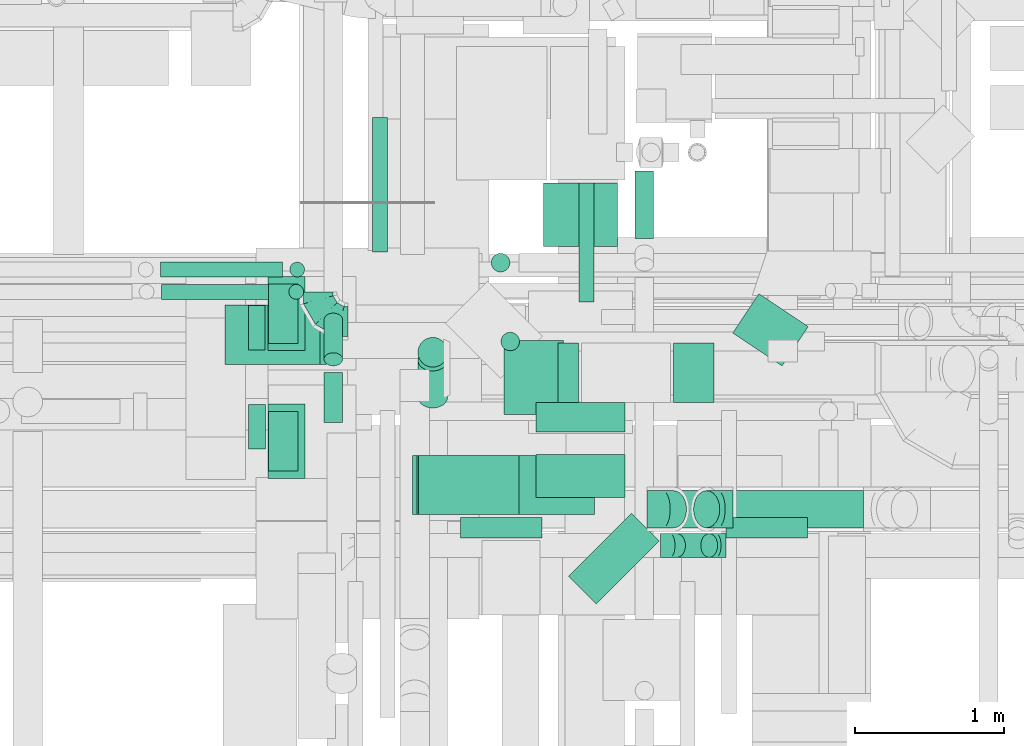
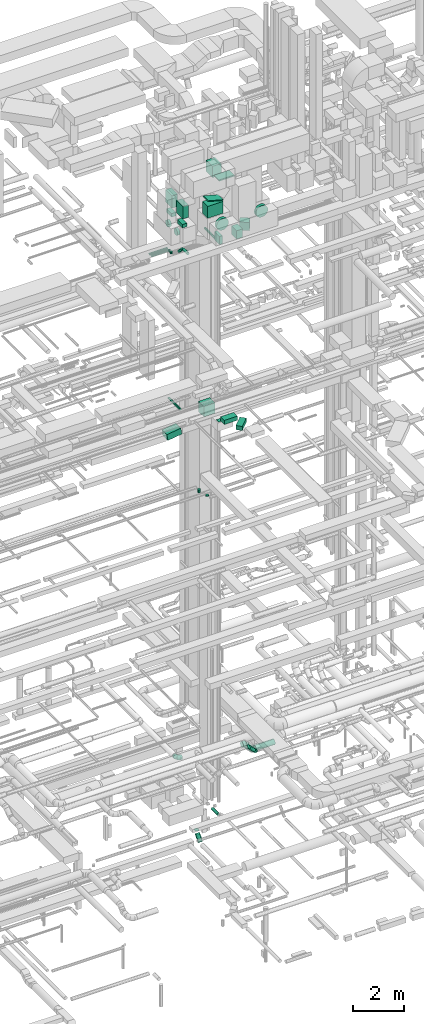
# One storey, part 171 of 337: 36 flow segments, 5 flow fittings.
"""IFC2X3 building model written with IfcOpenShell, lengths in millimetres."""

from ifc_helpers import new_model, entity, si_unit, converted_unit, derived_unit, direction, frame, frame_2d, origin, origin_2d_with_axis, place, context, subcontext, project, spatial, rectangle, circle, extrude, faceted_brep, source, transform, mapped, material, type_object, type_shapes, element, save


model = new_model("IFC2X3")

# Units and contexts
model_context = context("Model", 3, precision=0.01, world=origin(), true_north=direction((6.12303176911189e-17, 1.0)))
body_context = subcontext(model_context, "Body", "Model", "MODEL_VIEW")
ifc_project = project(units=[si_unit("LENGTHUNIT", "METRE", prefix="MILLI"), si_unit("AREAUNIT", "SQUARE_METRE"), si_unit("VOLUMEUNIT", "CUBIC_METRE"), converted_unit("PLANEANGLEUNIT", "DEGREE", entity("IfcRatioMeasure", 0.0174532925199433), si_unit("PLANEANGLEUNIT", "RADIAN"), dimensions=[0, 0, 0, 0, 0, 0, 0]), si_unit("MASSUNIT", "GRAM", prefix="KILO"), derived_unit("MASSDENSITYUNIT", [(si_unit("MASSUNIT", "GRAM", prefix="KILO"), 1), (si_unit("LENGTHUNIT", "METRE"), -3)]), derived_unit("MOMENTOFINERTIAUNIT", [(si_unit("LENGTHUNIT", "METRE"), 4)]), si_unit("TIMEUNIT", "SECOND"), si_unit("FREQUENCYUNIT", "HERTZ"), si_unit("THERMODYNAMICTEMPERATUREUNIT", "DEGREE_CELSIUS"), derived_unit("THERMALTRANSMITTANCEUNIT", [(si_unit("MASSUNIT", "GRAM", prefix="KILO"), 1), (si_unit("THERMODYNAMICTEMPERATUREUNIT", "KELVIN"), -1), (si_unit("TIMEUNIT", "SECOND"), -3)]), derived_unit("VOLUMETRICFLOWRATEUNIT", [(si_unit("LENGTHUNIT", "METRE"), 3), (si_unit("TIMEUNIT", "SECOND"), -1)]), derived_unit("MASSFLOWRATEUNIT", [(si_unit("MASSUNIT", "GRAM", prefix="KILO"), 1), (si_unit("TIMEUNIT", "SECOND"), -1)]), derived_unit("ROTATIONALFREQUENCYUNIT", [(si_unit("TIMEUNIT", "SECOND"), -1)]), si_unit("ELECTRICCURRENTUNIT", "AMPERE"), si_unit("ELECTRICVOLTAGEUNIT", "VOLT"), si_unit("POWERUNIT", "WATT"), si_unit("FORCEUNIT", "NEWTON", prefix="KILO"), si_unit("ILLUMINANCEUNIT", "LUX"), si_unit("LUMINOUSFLUXUNIT", "LUMEN"), si_unit("LUMINOUSINTENSITYUNIT", "CANDELA"), derived_unit("USERDEFINED", [(si_unit("MASSUNIT", "GRAM", prefix="KILO"), -1), (si_unit("LENGTHUNIT", "METRE"), -2), (si_unit("TIMEUNIT", "SECOND"), 3), (si_unit("LUMINOUSFLUXUNIT", "LUMEN"), 1)]), derived_unit("LINEARVELOCITYUNIT", [(si_unit("LENGTHUNIT", "METRE"), 1), (si_unit("TIMEUNIT", "SECOND"), -1)]), si_unit("PRESSUREUNIT", "PASCAL"), derived_unit("USERDEFINED", [(si_unit("LENGTHUNIT", "METRE"), -2), (si_unit("MASSUNIT", "GRAM", prefix="KILO"), 1), (si_unit("TIMEUNIT", "SECOND"), -2)]), derived_unit("LINEARFORCEUNIT", [(si_unit("MASSUNIT", "GRAM", prefix="KILO"), 1), (si_unit("LENGTHUNIT", "METRE"), 1), (si_unit("TIMEUNIT", "SECOND"), -2), (si_unit("LENGTHUNIT", "METRE"), -1)]), derived_unit("PLANARFORCEUNIT", [(si_unit("MASSUNIT", "GRAM", prefix="KILO"), 1), (si_unit("LENGTHUNIT", "METRE"), 1), (si_unit("TIMEUNIT", "SECOND"), -2), (si_unit("LENGTHUNIT", "METRE"), -2)])], contexts=[model_context])

# Site, building, storey
site_placement = place(None, origin())
site = spatial("IfcSite", under=ifc_project, at=site_placement, CompositionType="ELEMENT")
building_placement = place(site_placement, origin())
building = spatial("IfcBuilding", under=site, at=building_placement, CompositionType="ELEMENT")
storey_placement = place(building_placement, origin())
storey = spatial("IfcBuildingStorey", under=building, at=storey_placement, CompositionType="ELEMENT", Elevation=0.0)

# Flow segments
duct_segment_type_1 = type_object("IfcDuctSegmentType", PredefinedType="NOTDEFINED")
flow_segment_1_placement = place(storey_placement, frame((44370.22, 10356.34, 18475.0)))
element("IfcFlowSegment", 1, at=flow_segment_1_placement, inside=storey, type_object=duct_segment_type_1, context=body_context, shape_type="SweptSolid", body=[
    extrude(rectangle(XDim=425.486920000181, YDim=499.999999999999, at=origin_2d_with_axis()), frame((250.0, 212.74, 0.0), z_axis=(0.0, 0.0, 1.0), x_axis=(0.0, -1.0, 0.0)), (0.0, 0.0, 1.0), 499.999999999999),
])
flow_segment_2_placement = place(storey_placement, frame((44320.22, 9106.34, 18995.0)))
element("IfcFlowSegment", 2, at=flow_segment_2_placement, inside=storey, type_object=duct_segment_type_1, context=body_context, shape_type="SweptSolid", body=[
    extrude(rectangle(XDim=600.000000000002, YDim=200.0, at=origin_2d_with_axis()), frame((300.0, 100.0, 0.0)), (0.0, 0.0, 1.0), 5.00000000001836),
])
flow_segment_3_placement = place(storey_placement, frame((44320.22, 8665.74, 19150.0)))
element("IfcFlowSegment", 3, at=flow_segment_3_placement, inside=storey, type_object=duct_segment_type_1, context=body_context, shape_type="SweptSolid", body=[
    extrude(rectangle(XDim=290.603896932155, YDim=600.000000000002, at=origin_2d_with_axis()), frame((300.0, 145.3, 0.0), z_axis=(0.0, 0.0, 1.0), x_axis=(0.0, -1.0, 0.0)), (0.0, 0.0, 1.0), 199.999999999998),
])
flow_segment_4_placement = place(storey_placement, frame((44539.89, 7949.19, 19150.0)))
element("IfcFlowSegment", 4, at=flow_segment_4_placement, inside=storey, type_object=duct_segment_type_1, context=body_context, shape_type="SweptSolid", body=[
    extrude(rectangle(XDim=263.360030755663, YDim=600.000000000005, at=origin_2d_with_axis()), frame((305.24, 305.24, 0.0), z_axis=(0.0, 0.0, 1.0), x_axis=(0.707106781186543, -0.707106781186552, 0.0)), (0.0, 0.0, 1.0), 200.000000000002),
])
flow_segment_5_placement = place(storey_placement, frame((45246.69, 9306.23, 27350.0)))
element("IfcFlowSegment", 5, at=flow_segment_5_placement, inside=storey, type_object=duct_segment_type_1, context=body_context, shape_type="SweptSolid", body=[
    extrude(rectangle(XDim=272.617221517287, YDim=400.0, at=origin_2d_with_axis()), frame((136.31, 200.0, 0.0)), (0.0, 0.0, 1.0), 400.000000000004),
])
flow_segment_6_placement = place(storey_placement, frame((42228.62, 9560.56, 18554.77)))
element("IfcFlowSegment", 6, at=flow_segment_6_placement, inside=storey, type_object=duct_segment_type_1, context=body_context, shape_type="SweptSolid", body=[
    extrude(rectangle(XDim=299.999999999999, YDim=400.0, at=frame_2d((0.0, 0.0), x_axis=(0.0, 1.0))), frame((21.78, 200.0, 148.41), z_axis=(0.989404651307168, 0.0, 0.145184145042569), x_axis=(0.0, 1.0, 0.0)), (0.0, 0.0, 1.0), 644.993230885218),
])
flow_segment_7_placement = place(storey_placement, frame((43490.41, 8549.6, 29420.0)))
element("IfcFlowSegment", 7, at=flow_segment_7_placement, inside=storey, type_object=duct_segment_type_1, context=body_context, shape_type="SweptSolid", body=[
    extrude(rectangle(XDim=699.999999999997, YDim=400.0, at=origin_2d_with_axis()), frame((350.0, 200.0, 0.0)), (0.0, 0.0, 1.0), 574.173751206303),
])
flow_segment_8_placement = place(storey_placement, frame((43519.37, 8549.6, 30033.0)))
element("IfcFlowSegment", 8, at=flow_segment_8_placement, inside=storey, type_object=duct_segment_type_1, context=body_context, shape_type="SweptSolid", body=[
    extrude(rectangle(XDim=42.398794631677, YDim=400.0, at=origin_2d_with_axis()), frame((5.49, 200.0, 201.65), z_axis=(0.965925826289126, 0.0, -0.258819045102305), x_axis=(0.258819045102305, 0.0, 0.965925826289126)), (0.0, 0.0, 1.0), 699.999999999999),
])
flow_segment_9_placement = place(storey_placement, frame((44015.25, 8549.6, 31020.34)))
element("IfcFlowSegment", 9, at=flow_segment_9_placement, inside=storey, type_object=duct_segment_type_1, context=body_context, shape_type="SweptSolid", body=[
    extrude(rectangle(XDim=400.0, YDim=699.999999999997, at=origin_2d_with_axis()), frame((350.0, 200.0, 0.0), z_axis=(0.0, 0.0, 1.0), x_axis=(0.0, 1.0, 0.0)), (0.0, 0.0, 1.0), 59.6639512363934),
])
flow_segment_10_placement = place(storey_placement, frame((44105.04, 9223.67, 30750.0)))
element("IfcFlowSegment", 10, at=flow_segment_10_placement, inside=storey, type_object=duct_segment_type_1, context=body_context, shape_type="SweptSolid", body=[
    extrude(rectangle(XDim=399.999999999996, YDim=500.0, at=origin_2d_with_axis()), frame((200.0, 250.0, 0.0)), (0.0, 0.0, 1.0), 549.999999999988),
])
for number, where in (
    (11, (42515.03, 8793.67, 29587.0)),
    (12, (42515.03, 9653.67, 29587.0)),
):
    element("IfcFlowSegment", number, at=place(storey_placement, frame(where)), inside=storey, type_object=duct_segment_type_1, context=body_context, shape_type="SweptSolid", body=[
        extrude(rectangle(XDim=249.999999999995, YDim=500.0, at=origin_2d_with_axis()), frame((125.0, 250.0, 0.0), z_axis=(0.0, 0.0, 1.0), x_axis=(-1.0, 0.0, 0.0)), (0.0, 0.0, 1.0), 592.999999999878),
    ])
for number, where in (
    (13, (42520.03, 8843.67, 29120.0)),
    (14, (42520.03, 9703.67, 29120.0)),
):
    element("IfcFlowSegment", number, at=place(storey_placement, frame(where)), inside=storey, type_object=duct_segment_type_1, context=body_context, shape_type="SweptSolid", body=[
        extrude(rectangle(XDim=200.000000000007, YDim=400.0, at=origin_2d_with_axis()), frame((100.0, 200.0, 0.0), z_axis=(0.0, 0.0, 1.0), x_axis=(-1.0, 0.0, 0.0)), (0.0, 0.0, 1.0), 166.999975000393),
    ])
flow_segment_11_placement = place(storey_placement, frame((45644.15, 9551.33, 27350.0)))
element("IfcFlowSegment", 15, at=flow_segment_11_placement, inside=storey, type_object=duct_segment_type_1, context=body_context, shape_type="SweptSolid", body=[
    extrude(rectangle(XDim=317.471052566254, YDim=400.000000000003, at=origin_2d_with_axis()), frame((254.45, 242.98, 0.0), z_axis=(0.0, 0.0, 1.0), x_axis=(0.554353814771923, 0.832281111192496, 0.0)), (0.0, 0.0, 1.0), 400.000000000004),
])
flow_segment_12_placement = place(storey_placement, frame((44470.0, 9306.23, 27350.0)))
element("IfcFlowSegment", 16, at=flow_segment_12_placement, inside=storey, type_object=duct_segment_type_1, context=body_context, shape_type="SweptSolid", body=[
    extrude(rectangle(XDim=136.690475583719, YDim=400.0, at=origin_2d_with_axis()), frame((68.35, 200.0, 0.0)), (0.0, 0.0, 1.0), 400.000000000004),
])
duct_segment_type_2 = type_object("IfcDuctSegmentType", PredefinedType="NOTDEFINED")
flow_segment_13_placement = place(storey_placement, frame((43524.07, 9541.55, -673.23)))
element("IfcFlowSegment", 17, at=flow_segment_13_placement, inside=storey, type_object=duct_segment_type_2, context=body_context, shape_type="SweptSolid", body=[
    extrude(circle(Radius=100.0, at=origin_2d_with_axis()), frame((101.6, 101.6, 0.0), z_axis=(0.0, 0.0, 1.0), x_axis=(0.0, -1.0, 0.0)), (0.0, 0.0, 1.0), 3.2271929929153),
])
flow_segment_14_placement = place(storey_placement, frame((43218.73, 10319.9, 19198.4)))
element("IfcFlowSegment", 18, at=flow_segment_14_placement, inside=storey, type_object=duct_segment_type_2, context=body_context, shape_type="SweptSolid", body=[
    extrude(circle(Radius=50.0, at=origin_2d_with_axis()), frame((51.6, 0.0, 51.6), z_axis=(0.0, 1.0, 0.0), x_axis=(1.0, 0.0, 0.0)), (0.0, 0.0, 1.0), 904.999999988056),
])
flow_segment_15_placement = place(storey_placement, frame((44083.13, 9651.59, 15165.0)))
element("IfcFlowSegment", 19, at=flow_segment_15_placement, inside=storey, type_object=duct_segment_type_2, context=body_context, shape_type="SweptSolid", body=[
    extrude(circle(Radius=62.5, at=origin_2d_with_axis()), frame((64.1, 64.1, 0.0), z_axis=(0.0, 0.0, 1.0), x_axis=(0.0, 1.0, 0.0)), (0.0, 0.0, 1.0), 9.9999996080713),
])
flow_segment_16_placement = place(storey_placement, frame((44017.93, 10182.2, 15025.0)))
element("IfcFlowSegment", 20, at=flow_segment_16_placement, inside=storey, type_object=duct_segment_type_2, context=body_context, shape_type="SweptSolid", body=[
    extrude(circle(Radius=62.5, at=origin_2d_with_axis()), frame((64.1, 64.1, 0.0), z_axis=(0.0, 0.0, 1.0), x_axis=(0.0, 1.0, 0.0)), (0.0, 0.0, 1.0), 149.999999999981),
])
flow_segment_17_placement = place(storey_placement, frame((45597.36, 8394.6, 28745.35)))
element("IfcFlowSegment", 21, at=flow_segment_17_placement, inside=storey, type_object=duct_segment_type_2, context=body_context, shape_type="SweptSolid", body=[
    extrude(circle(Radius=275.0, at=origin_2d_with_axis()), frame((276.6, 0.0, 276.6), z_axis=(0.0, 1.0, 0.0), x_axis=(-1.0, 0.0, 0.0)), (0.0, 0.0, 1.0), 135.000019999968),
])
flow_segment_18_placement = place(storey_placement, frame((43810.74, 8394.6, 28745.35)))
element("IfcFlowSegment", 22, at=flow_segment_18_placement, inside=storey, type_object=duct_segment_type_2, context=body_context, shape_type="SweptSolid", body=[
    extrude(circle(Radius=275.0, at=origin_2d_with_axis()), frame((276.6, 0.0, 276.6), z_axis=(0.0, 1.0, 0.0), x_axis=(1.0, 0.0, 0.0)), (0.0, 0.0, 1.0), 135.000019999971),
])
flow_segment_19_placement = place(storey_placement, frame((42385.03, 8988.56, 28643.02)))
element("IfcFlowSegment", 23, at=flow_segment_19_placement, inside=storey, type_object=duct_segment_type_2, context=body_context, shape_type="SweptSolid", body=[
    extrude(circle(Radius=150.0, at=origin_2d_with_axis()), frame((0.0, 151.6, 151.6), z_axis=(1.0, 0.0, 0.0), x_axis=(0.0, 1.0, 0.0)), (0.0, 0.0, 1.0), 113.999974999942),
])
flow_segment_20_placement = place(storey_placement, frame((42385.03, 9658.56, 28643.02)))
element("IfcFlowSegment", 24, at=flow_segment_20_placement, inside=storey, type_object=duct_segment_type_2, context=body_context, shape_type="SweptSolid", body=[
    extrude(circle(Radius=150.0, at=origin_2d_with_axis()), frame((0.0, 151.6, 151.6), z_axis=(1.0, 0.0, 0.0), x_axis=(0.0, -1.0, 0.0)), (0.0, 0.0, 1.0), 112.533814999979),
])
flow_segment_21_placement = place(storey_placement, frame((44609.78, 9981.53, 27148.4)))
element("IfcFlowSegment", 25, at=flow_segment_21_placement, inside=storey, type_object=duct_segment_type_2, context=body_context, shape_type="SweptSolid", body=[
    extrude(circle(Radius=50.0, at=origin_2d_with_axis()), frame((51.6, 0.0, 51.6), z_axis=(0.0, 1.0, 0.0), x_axis=(-1.0, 0.0, 0.0)), (0.0, 0.0, 1.0), 800.304484299489),
])
flow_segment_22_placement = place(storey_placement, frame((42892.15, 9169.98, 27475.9)))
element("IfcFlowSegment", 26, at=flow_segment_22_placement, inside=storey, type_object=duct_segment_type_2, context=body_context, shape_type="SweptSolid", body=[
    extrude(circle(Radius=62.5, at=origin_2d_with_axis()), frame((64.1, 0.0, 64.1), z_axis=(0.0, 1.0, 0.0), x_axis=(1.0, 0.0, 0.0)), (0.0, 0.0, 1.0), 337.623304703358),
])
flow_segment_23_placement = place(storey_placement, frame((42892.15, 9550.2, 27190.82)))
element("IfcFlowSegment", 27, at=flow_segment_23_placement, inside=storey, type_object=duct_segment_type_2, context=body_context, shape_type="SweptSolid", body=[
    extrude(circle(Radius=62.5, at=origin_2d_with_axis()), frame((64.1, 45.79, 312.57), z_axis=(0.0, 0.707106781186546, -0.707106781186549), x_axis=(1.0, 0.0, 0.0)), (0.0, 0.0, 1.0), 377.279220613566),
])
flow_segment_24_placement = place(storey_placement, frame((41793.23, 10148.35, 27248.4)))
element("IfcFlowSegment", 28, at=flow_segment_24_placement, inside=storey, type_object=duct_segment_type_2, context=body_context, shape_type="SweptSolid", body=[
    extrude(circle(Radius=50.0, at=origin_2d_with_axis()), frame((0.0, 51.6, 51.6), z_axis=(1.0, 0.0, 0.0), x_axis=(0.0, 1.0, 0.0)), (0.0, 0.0, 1.0), 819.50000000016),
])
flow_segment_25_placement = place(storey_placement, frame((42661.13, 10148.35, 27100.0)))
element("IfcFlowSegment", 29, at=flow_segment_25_placement, inside=storey, type_object=duct_segment_type_2, context=body_context, shape_type="SweptSolid", body=[
    extrude(circle(Radius=50.0, at=origin_2d_with_axis()), frame((51.6, 51.6, 0.0), z_axis=(0.0, 0.0, 1.0), x_axis=(0.0, 1.0, 0.0)), (0.0, 0.0, 1.0), 100.000000000961),
])
flow_segment_26_placement = place(storey_placement, frame((41799.27, 9998.34, 27248.4)))
element("IfcFlowSegment", 30, at=flow_segment_26_placement, inside=storey, type_object=duct_segment_type_2, context=body_context, shape_type="SweptSolid", body=[
    extrude(circle(Radius=50.0, at=origin_2d_with_axis()), frame((0.0, 51.6, 51.6), z_axis=(1.0, 0.0, 0.0), x_axis=(0.0, 1.0, 0.0)), (0.0, 0.0, 1.0), 807.3966805263),
])
flow_segment_27_placement = place(storey_placement, frame((42655.07, 9998.34, 27100.0)))
element("IfcFlowSegment", 31, at=flow_segment_27_placement, inside=storey, type_object=duct_segment_type_2, context=body_context, shape_type="SweptSolid", body=[
    extrude(circle(Radius=50.0, at=origin_2d_with_axis()), frame((51.6, 51.6, 0.0), z_axis=(0.0, 0.0, 1.0), x_axis=(0.0, -1.0, 0.0)), (0.0, 0.0, 1.0), 100.000000000003),
])
flow_segment_28_placement = place(storey_placement, frame((45646.1, 8460.07, 3053.4)))
element("IfcFlowSegment", 32, at=flow_segment_28_placement, inside=storey, type_object=duct_segment_type_2, context=body_context, shape_type="SweptSolid", body=[
    extrude(circle(Radius=125.0, at=origin_2d_with_axis()), frame((0.0, 126.6, 126.6), z_axis=(1.0, 0.0, 0.0), x_axis=(0.0, 1.0, 0.0)), (0.0, 0.0, 1.0), 878.613218813486),
])
flow_segment_29_placement = place(storey_placement, frame((45155.79, 8460.07, 3163.24)))
element("IfcFlowSegment", 33, at=flow_segment_29_placement, inside=storey, type_object=duct_segment_type_2, context=body_context, shape_type="SweptSolid", body=[
    extrude(circle(Radius=125.0, at=origin_2d_with_axis()), frame((313.54, 126.6, 89.98), z_axis=(-0.7071067811865, 0.0, 0.707106781186595), x_axis=(0.0, 1.0, 0.0)), (0.0, 0.0, 1.0), 316.152236891543),
])
flow_segment_30_placement = place(storey_placement, frame((45212.04, 8260.92, 3228.7)))
element("IfcFlowSegment", 34, at=flow_segment_30_placement, inside=storey, type_object=duct_segment_type_2, context=body_context, shape_type="SweptSolid", body=[
    extrude(circle(Radius=80.0, at=origin_2d_with_axis()), frame((274.44, 81.6, 58.16), z_axis=(-0.707106781186463, 0.0, 0.707106781186632), x_axis=(0.0, -1.0, 0.0)), (0.0, 0.0, 1.0), 305.857864376165),
])
flow_segment_31_placement = place(storey_placement, frame((44986.38, 10409.63, -964.1)))
element("IfcFlowSegment", 35, at=flow_segment_31_placement, inside=storey, type_object=duct_segment_type_2, context=body_context, shape_type="SweptSolid", body=[
    extrude(circle(Radius=62.5, at=origin_2d_with_axis()), frame((64.1, 0.0, 64.1), z_axis=(0.0, 1.0, 0.0), x_axis=(-1.0, 0.0, 0.0)), (0.0, 0.0, 1.0), 453.943304703355),
])
flow_segment_32_placement = place(storey_placement, frame((43524.07, 9266.66, -1152.33)))
element("IfcFlowSegment", 36, at=flow_segment_32_placement, inside=storey, type_object=duct_segment_type_2, context=body_context, shape_type="SweptSolid", body=[
    extrude(circle(Radius=100.0, at=origin_2d_with_axis()), frame((101.6, 75.91, 68.51), z_axis=(0.0, 0.669130606358857, 0.743144825477396), x_axis=(-1.0, 0.0, 0.0)), (0.0, 0.0, 1.0), 372.434547773708),
])

# Flow fittings
ifc_material = material()
duct_fitting_type_1 = type_object("IfcDuctFittingType", PredefinedType="NOTDEFINED", material=ifc_material)
shared_shape_1 = source(origin(), body_context, "Body", "Brep", [
    faceted_brep([(-200.0, 0.0, -100.0), (-200.0, -25.88, -96.59), (-200.0, -50.0, -86.6), (-200.0, -70.71, -70.71), (-200.0, -86.6, -50.0), (-200.0, -96.59, -25.88), (-200.0, -100.0, 0.0), (-200.0, -96.59, 25.88), (-200.0, -86.6, 50.0), (-200.0, -70.71, 70.71), (-200.0, -50.0, 86.6), (-200.0, -25.88, 96.59), (-200.0, 0.0, 100.0), (-200.0, 25.88, 96.59), (-200.0, 50.0, 86.6), (-200.0, 70.71, 70.71), (-200.0, 86.6, 50.0), (-200.0, 96.59, 25.88), (-200.0, 100.0, 0.0), (-200.0, 96.59, -25.88), (-200.0, 86.6, -50.0), (-200.0, 70.71, -70.71), (-200.0, 50.0, -86.6), (-200.0, 25.88, -96.59), (-153.35, 25.88, 96.59), (-159.81, 50.0, 86.6), (-146.41, 0.0, 100.0), (-165.36, 70.71, 70.71), (-172.29, 96.59, 25.88), (-173.21, 100.0, 0.0), (-169.62, 86.6, 50.0), (-169.62, 86.6, -50.0), (-165.36, 70.71, -70.71), (-172.29, 96.59, -25.88), (-153.35, 25.88, -96.59), (-146.41, 0.0, -100.0), (-159.81, 50.0, -86.6), (-139.48, -25.88, -96.59), (-133.01, -50.0, -86.6), (-127.46, -70.71, -70.71), (-123.21, -86.6, -50.0), (-120.53, -96.59, -25.88), (-119.62, -100.0, 0.0), (-120.53, -96.59, 25.88), (-123.21, -86.6, 50.0), (-127.46, -70.71, 70.71), (-133.01, -50.0, 86.6), (-139.48, -25.88, 96.59), (-72.54, 72.54, 96.59), (-90.19, 90.19, 86.6), (-53.59, 53.59, 100.0), (-105.35, 105.35, 70.71), (-116.99, 116.99, 50.0), (-124.3, 124.3, 25.88), (-126.79, 126.79, 0.0), (-124.3, 124.3, -25.88), (-116.99, 116.99, -50.0), (-105.35, 105.35, -70.71), (-72.54, 72.54, -96.59), (-53.59, 53.59, -100.0), (-90.19, 90.19, -86.6), (-34.64, 34.64, -96.59), (-16.99, 16.99, -86.6), (-1.83, 1.83, -70.71), (9.81, -9.81, -50.0), (17.12, -17.12, -25.88), (19.62, -19.62, 0.0), (17.12, -17.12, 25.88), (9.81, -9.81, 50.0), (-1.83, 1.83, 70.71), (-16.99, 16.99, 86.6), (-34.64, 34.64, 96.59), (-25.88, 153.35, 96.59), (-50.0, 159.81, 86.6), (0.0, 146.41, 100.0), (-70.71, 165.36, 70.71), (-86.6, 169.62, 50.0), (-96.59, 172.29, 25.88), (-100.0, 173.21, 0.0), (-96.59, 172.29, -25.88), (-86.6, 169.62, -50.0), (-70.71, 165.36, -70.71), (-25.88, 153.35, -96.59), (0.0, 146.41, -100.0), (-50.0, 159.81, -86.6), (25.88, 139.48, -96.59), (50.0, 133.01, -86.6), (70.71, 127.46, -70.71), (86.6, 123.21, -50.0), (96.59, 120.53, -25.88), (100.0, 119.62, 0.0), (96.59, 120.53, 25.88), (86.6, 123.21, 50.0), (70.71, 127.46, 70.71), (50.0, 133.01, 86.6), (25.88, 139.48, 96.59), (-25.88, 200.0, -96.59), (-50.0, 200.0, -86.6), (-70.71, 200.0, -70.71), (-86.6, 200.0, -50.0), (-96.59, 200.0, -25.88), (-100.0, 200.0, 0.0), (-96.59, 200.0, 25.88), (-86.6, 200.0, 50.0), (-70.71, 200.0, 70.71), (-50.0, 200.0, 86.6), (-25.88, 200.0, 96.59), (0.0, 200.0, 100.0), (25.88, 200.0, 96.59), (50.0, 200.0, 86.6), (70.71, 200.0, 70.71), (86.6, 200.0, 50.0), (96.59, 200.0, 25.88), (100.0, 200.0, 0.0), (96.59, 200.0, -25.88), (86.6, 200.0, -50.0), (70.71, 200.0, -70.71), (50.0, 200.0, -86.6), (25.88, 200.0, -96.59), (0.0, 200.0, -100.0)], [[[0, 1, 2, 3, 4, 5, 6, 7, 8, 9, 10, 11, 12, 13, 14, 15, 16, 17, 18, 19, 20, 21, 22, 23]], [[24, 25, 14, 13]], [[26, 24, 13, 12]], [[14, 25, 27, 15]], [[28, 29, 18, 17]], [[30, 28, 17, 16]], [[15, 27, 30, 16]], [[20, 31, 32, 21]], [[33, 31, 20, 19]], [[18, 29, 33, 19]], [[34, 35, 0, 23]], [[36, 34, 23, 22]], [[32, 36, 22, 21]], [[1, 0, 35, 37]], [[2, 1, 37, 38]], [[38, 39, 3, 2]], [[5, 4, 40, 41]], [[6, 5, 41, 42]], [[39, 40, 4, 3]], [[6, 42, 43, 7]], [[7, 43, 44, 8]], [[8, 44, 45, 9]], [[9, 45, 46, 10]], [[10, 46, 47, 11]], [[26, 12, 11, 47]], [[48, 49, 25, 24]], [[50, 48, 24, 26]], [[27, 25, 49, 51]], [[52, 53, 28, 30]], [[51, 52, 30, 27]], [[29, 28, 53, 54]], [[55, 56, 31, 33]], [[54, 55, 33, 29]], [[32, 31, 56, 57]], [[58, 59, 35, 34]], [[60, 58, 34, 36]], [[57, 60, 36, 32]], [[37, 35, 59, 61]], [[38, 37, 61, 62]], [[39, 38, 62, 63]], [[41, 40, 64, 65]], [[42, 41, 65, 66]], [[63, 64, 40, 39]], [[43, 42, 66, 67]], [[44, 43, 67, 68]], [[68, 69, 45, 44]], [[46, 45, 69, 70]], [[47, 46, 70, 71]], [[26, 47, 71, 50]], [[72, 73, 49, 48]], [[74, 72, 48, 50]], [[51, 49, 73, 75]], [[76, 77, 53, 52]], [[75, 76, 52, 51]], [[54, 53, 77, 78]], [[79, 80, 56, 55]], [[78, 79, 55, 54]], [[57, 56, 80, 81]], [[82, 83, 59, 58]], [[84, 82, 58, 60]], [[81, 84, 60, 57]], [[61, 59, 83, 85]], [[62, 61, 85, 86]], [[63, 62, 86, 87]], [[65, 64, 88, 89]], [[66, 65, 89, 90]], [[87, 88, 64, 63]], [[67, 66, 90, 91]], [[68, 67, 91, 92]], [[92, 93, 69, 68]], [[70, 69, 93, 94]], [[71, 70, 94, 95]], [[50, 71, 95, 74]], [[96, 97, 98, 99, 100, 101, 102, 103, 104, 105, 106, 107, 108, 109, 110, 111, 112, 113, 114, 115, 116, 117, 118, 119]], [[72, 74, 107, 106]], [[73, 72, 106, 105]], [[75, 73, 105, 104]], [[102, 101, 78, 77]], [[103, 102, 77, 76]], [[75, 104, 103, 76]], [[78, 101, 100, 79]], [[79, 100, 99, 80]], [[80, 99, 98, 81]], [[84, 97, 96, 82]], [[82, 96, 119, 83]], [[84, 81, 98, 97]], [[118, 117, 86, 85]], [[119, 118, 85, 83]], [[116, 87, 86, 117]], [[88, 115, 114, 89]], [[89, 114, 113, 90]], [[115, 88, 87, 116]], [[91, 90, 113, 112]], [[92, 91, 112, 111]], [[111, 110, 93, 92]], [[95, 94, 109, 108]], [[74, 95, 108, 107]], [[110, 109, 94, 93]]]),
])
type_shapes(duct_fitting_type_1, [shared_shape_1])
flow_fitting_placement = place(storey_placement, frame((42855.12, 9850.0, 2900.0), z_axis=(0.0, 0.0, 1.0), x_axis=(0.0, -1.0, 0.0)))
element("IfcFlowFitting", 37, at=flow_fitting_placement, inside=storey, type_object=duct_fitting_type_1, material=ifc_material, context=body_context, shape_type="MappedRepresentation", body=[
    mapped(shared_shape_1, transform((0.0, 0.0, 0.0), scale=1.0)),
])
duct_fitting_type_2 = type_object("IfcDuctFittingType", PredefinedType="NOTDEFINED", material=ifc_material)
shared_shape_2 = source(origin(), body_context, "Body", "Brep", [
    faceted_brep([(-66.27, 0.0, -80.0), (-66.27, -20.71, -77.27), (-66.27, -40.0, -69.28), (-66.27, -56.57, -56.57), (-66.27, -69.28, -40.0), (-66.27, -77.27, -20.71), (-66.27, -80.0, 0.0), (-66.27, -77.27, 20.71), (-66.27, -69.28, 40.0), (-66.27, -56.57, 56.57), (-66.27, -40.0, 69.28), (-66.27, -20.71, 77.27), (-66.27, 0.0, 80.0), (-66.27, 20.71, 77.27), (-66.27, 40.0, 69.28), (-66.27, 56.57, 56.57), (-66.27, 69.28, 40.0), (-66.27, 77.27, 20.71), (-66.27, 80.0, 0.0), (-66.27, 77.27, -20.71), (-66.27, 69.28, -40.0), (-66.27, 56.57, -56.57), (-66.27, 40.0, -69.28), (-66.27, 20.71, -77.27), (-8.58, 20.71, 77.27), (-16.57, 40.0, 69.28), (0.0, 0.0, 80.0), (-23.43, 56.57, 56.57), (-28.7, 69.28, 40.0), (-32.01, 77.27, 20.71), (-33.14, 80.0, 0.0), (-32.01, 77.27, -20.71), (-28.7, 69.28, -40.0), (-23.43, 56.57, -56.57), (-8.58, 20.71, -77.27), (0.0, 0.0, -80.0), (-16.57, 40.0, -69.28), (8.58, -20.71, -77.27), (16.57, -40.0, -69.28), (23.43, -56.57, -56.57), (28.7, -69.28, -40.0), (32.01, -77.27, -20.71), (33.14, -80.0, 0.0), (32.01, -77.27, 20.71), (28.7, -69.28, 40.0), (23.43, -56.57, 56.57), (16.57, -40.0, 69.28), (8.58, -20.71, 77.27), (46.86, 46.86, 80.0), (32.22, 61.5, 77.27), (18.58, 75.15, 69.28), (6.86, 86.86, 56.57), (-2.13, 95.85, 40.0), (-7.78, 101.5, 20.71), (-9.71, 103.43, 0.0), (-7.78, 101.5, -20.71), (-2.13, 95.85, -40.0), (6.86, 86.86, -56.57), (18.58, 75.15, -69.28), (32.22, 61.5, -77.27), (46.86, 46.86, -80.0), (61.5, 32.22, -77.27), (75.15, 18.58, -69.28), (86.86, 6.86, -56.57), (95.85, -2.13, -40.0), (101.5, -7.78, -20.71), (103.43, -9.71, 0.0), (101.5, -7.78, 20.71), (95.85, -2.13, 40.0), (86.86, 6.86, 56.57), (75.15, 18.58, 69.28), (61.5, 32.22, 77.27)], [[[0, 1, 2, 3, 4, 5, 6, 7, 8, 9, 10, 11, 12, 13, 14, 15, 16, 17, 18, 19, 20, 21, 22, 23]], [[24, 25, 14, 13]], [[26, 24, 13, 12]], [[14, 25, 27, 15]], [[28, 29, 17, 16]], [[28, 16, 15, 27]], [[30, 18, 17, 29]], [[31, 32, 20, 19]], [[30, 31, 19, 18]], [[32, 33, 21, 20]], [[34, 35, 0, 23]], [[36, 34, 23, 22]], [[33, 36, 22, 21]], [[1, 0, 35, 37]], [[2, 1, 37, 38]], [[38, 39, 3, 2]], [[5, 4, 40, 41]], [[6, 5, 41, 42]], [[39, 40, 4, 3]], [[6, 42, 43, 7]], [[7, 43, 44, 8]], [[8, 44, 45, 9]], [[9, 45, 46, 10]], [[10, 46, 47, 11]], [[26, 12, 11, 47]], [[24, 26, 48, 49]], [[25, 24, 49, 50]], [[27, 25, 50, 51]], [[29, 28, 52, 53]], [[30, 29, 53, 54]], [[51, 52, 28, 27]], [[30, 54, 55, 31]], [[31, 55, 56, 32]], [[57, 33, 32, 56]], [[36, 58, 59, 34]], [[34, 59, 60, 35]], [[58, 36, 33, 57]], [[35, 60, 61, 37]], [[37, 61, 62, 38]], [[63, 39, 38, 62]], [[40, 64, 65, 41]], [[41, 65, 66, 42]], [[64, 40, 39, 63]], [[43, 42, 66, 67]], [[44, 43, 67, 68]], [[68, 69, 45, 44]], [[47, 46, 70, 71]], [[26, 47, 71, 48]], [[69, 70, 46, 45]], [[59, 58, 57, 56, 55, 54, 53, 52, 51, 50, 49, 48, 71, 70, 69, 68, 67, 66, 65, 64, 63, 62, 61, 60]]]),
])
type_shapes(duct_fitting_type_2, [shared_shape_2])
for number, where, z_axis, x_axis in (
    (38, (45533.34, 8342.51, 3240.0), (0.0, -1.0, 0.0), (0.707106781186459, 0.0, -0.707106781186636)),
    (39, (45223.34, 8342.51, 3550.0), (0.0, -1.0, 0.0), (-0.707106781186366, 0.0, 0.707106781186729)),
):
    element("IfcFlowFitting", number, at=place(storey_placement, frame(where, z_axis=z_axis, x_axis=x_axis)), inside=storey, type_object=duct_fitting_type_2, material=ifc_material, context=body_context, shape_type="MappedRepresentation", body=[
        mapped(shared_shape_2, transform((0.0, 0.0, 0.0), scale=1.0)),
    ])
duct_fitting_type_3 = type_object("IfcDuctFittingType", PredefinedType="NOTDEFINED", material=ifc_material)
shared_shape_3 = source(origin(), body_context, "Body", "Brep", [
    faceted_brep([(-103.55, 0.0, -125.0), (-103.55, -32.35, -120.74), (-103.55, -62.5, -108.25), (-103.55, -88.39, -88.39), (-103.55, -108.25, -62.5), (-103.55, -120.74, -32.35), (-103.55, -125.0, 0.0), (-103.55, -120.74, 32.35), (-103.55, -108.25, 62.5), (-103.55, -88.39, 88.39), (-103.55, -62.5, 108.25), (-103.55, -32.35, 120.74), (-103.55, 0.0, 125.0), (-103.55, 32.35, 120.74), (-103.55, 62.5, 108.25), (-103.55, 88.39, 88.39), (-103.55, 108.25, 62.5), (-103.55, 120.74, 32.35), (-103.55, 125.0, 0.0), (-103.55, 120.74, -32.35), (-103.55, 108.25, -62.5), (-103.55, 88.39, -88.39), (-103.55, 62.5, -108.25), (-103.55, 32.35, -120.74), (-13.4, 32.35, 120.74), (-25.89, 62.5, 108.25), (0.0, 0.0, 125.0), (-36.61, 88.39, 88.39), (-44.84, 108.25, 62.5), (-50.01, 120.74, 32.35), (-51.78, 125.0, 0.0), (-50.01, 120.74, -32.35), (-44.84, 108.25, -62.5), (-36.61, 88.39, -88.39), (-13.4, 32.35, -120.74), (0.0, 0.0, -125.0), (-25.89, 62.5, -108.25), (13.4, -32.35, -120.74), (25.89, -62.5, -108.25), (36.61, -88.39, -88.39), (44.84, -108.25, -62.5), (50.01, -120.74, -32.35), (51.78, -125.0, 0.0), (50.01, -120.74, 32.35), (44.84, -108.25, 62.5), (36.61, -88.39, 88.39), (25.89, -62.5, 108.25), (13.4, -32.35, 120.74), (73.22, 73.22, 125.0), (50.35, 96.1, 120.74), (29.03, 117.42, 108.25), (10.72, 135.72, 88.39), (-3.32, 149.77, 62.5), (-12.15, 158.6, 32.35), (-15.17, 161.61, 0.0), (-12.15, 158.6, -32.35), (-3.32, 149.77, -62.5), (10.72, 135.72, -88.39), (29.03, 117.42, -108.25), (50.35, 96.1, -120.74), (73.22, 73.22, -125.0), (96.1, 50.35, -120.74), (117.42, 29.03, -108.25), (135.72, 10.72, -88.39), (149.77, -3.32, -62.5), (158.6, -12.15, -32.35), (161.61, -15.17, 0.0), (158.6, -12.15, 32.35), (149.77, -3.32, 62.5), (135.72, 10.72, 88.39), (117.42, 29.03, 108.25), (96.1, 50.35, 120.74)], [[[0, 1, 2, 3, 4, 5, 6, 7, 8, 9, 10, 11, 12, 13, 14, 15, 16, 17, 18, 19, 20, 21, 22, 23]], [[24, 25, 14, 13]], [[26, 24, 13, 12]], [[14, 25, 27, 15]], [[28, 29, 17, 16]], [[28, 16, 15, 27]], [[30, 18, 17, 29]], [[31, 32, 20, 19]], [[30, 31, 19, 18]], [[32, 33, 21, 20]], [[34, 35, 0, 23]], [[36, 34, 23, 22]], [[33, 36, 22, 21]], [[1, 0, 35, 37]], [[2, 1, 37, 38]], [[38, 39, 3, 2]], [[5, 4, 40, 41]], [[6, 5, 41, 42]], [[39, 40, 4, 3]], [[6, 42, 43, 7]], [[7, 43, 44, 8]], [[8, 44, 45, 9]], [[9, 45, 46, 10]], [[10, 46, 47, 11]], [[26, 12, 11, 47]], [[24, 26, 48, 49]], [[25, 24, 49, 50]], [[27, 25, 50, 51]], [[29, 28, 52, 53]], [[30, 29, 53, 54]], [[51, 52, 28, 27]], [[30, 54, 55, 31]], [[31, 55, 56, 32]], [[57, 33, 32, 56]], [[36, 58, 59, 34]], [[34, 59, 60, 35]], [[58, 36, 33, 57]], [[35, 60, 61, 37]], [[37, 61, 62, 38]], [[63, 39, 38, 62]], [[40, 64, 65, 41]], [[41, 65, 66, 42]], [[64, 40, 39, 63]], [[43, 42, 66, 67]], [[44, 43, 67, 68]], [[68, 69, 45, 44]], [[47, 46, 70, 71]], [[26, 47, 71, 48]], [[69, 70, 46, 45]], [[59, 58, 57, 56, 55, 54, 53, 52, 51, 50, 49, 48, 71, 70, 69, 68, 67, 66, 65, 64, 63, 62, 61, 60]]]),
])
type_shapes(duct_fitting_type_3, [shared_shape_3])
for number, where, z_axis, x_axis in (
    (40, (45542.55, 8586.67, 3180.0), (0.0, 1.0, 0.0), (-1.0, 0.0, 0.0)),
    (41, (45172.55, 8586.67, 3550.0), (0.0, -1.0, 0.0), (-0.707106781186501, 0.0, 0.707106781186594)),
):
    element("IfcFlowFitting", number, at=place(storey_placement, frame(where, z_axis=z_axis, x_axis=x_axis)), inside=storey, type_object=duct_fitting_type_3, material=ifc_material, context=body_context, shape_type="MappedRepresentation", body=[
        mapped(shared_shape_3, transform((0.0, 0.0, 0.0), scale=1.0)),
    ])

save(model, "model.ifc")
